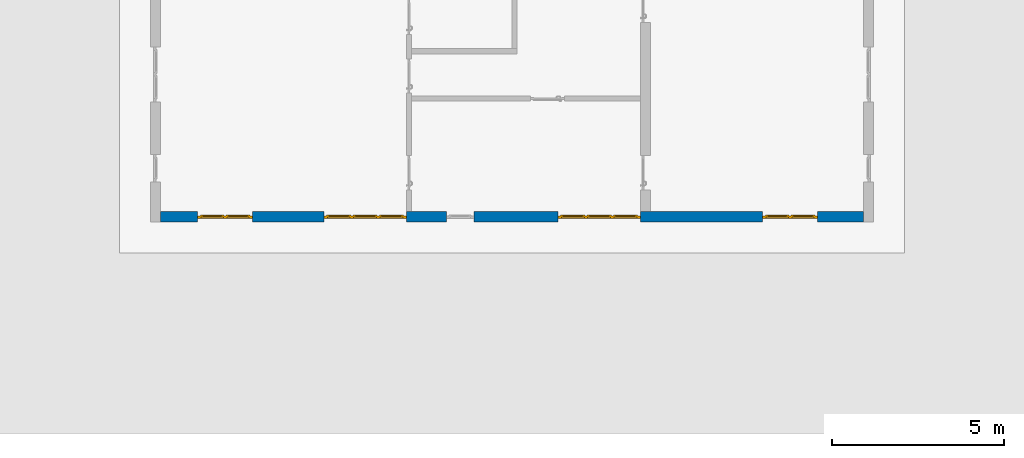
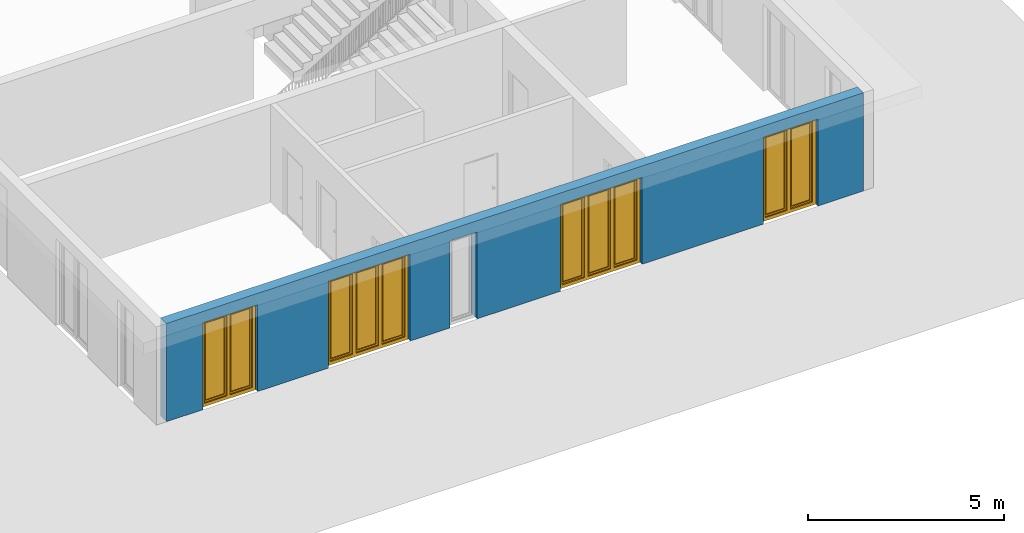
# One storey, part 5 of 23: 4 windows, 1 wall, 5 openings.
"""IFC4 building model written with IfcOpenShell, lengths in metres."""

from ifc_helpers import new_model, entity, si_unit, converted_unit, derived_unit, direction, frame, origin_with_axes, place, context, subcontext, project, spatial, polygons, source, transform, mapped, material, type_object, element, fill, save


model = new_model("IFC4")

# Units and contexts
model_context = context("Model", 3, precision=1e-05, world=origin_with_axes(), true_north=direction((0.0, 1.0)))
body_context = subcontext(model_context, "Body", "Model", "MODEL_VIEW")
ifc_project = project(units=[si_unit("LENGTHUNIT", "METRE"), si_unit("AREAUNIT", "SQUARE_METRE"), si_unit("VOLUMEUNIT", "CUBIC_METRE"), converted_unit("PLANEANGLEUNIT", "DEGREE", entity("IfcPlaneAngleMeasure", 0.0174532925199), si_unit("PLANEANGLEUNIT", "RADIAN"), dimensions=[0, 0, 0, 0, 0, 0, 0]), converted_unit("TIMEUNIT", "Year", entity("IfcTimeMeasure", 31556926.0), si_unit("TIMEUNIT", "SECOND"), dimensions=[0, 0, 1, 0, 0, 0, 0]), si_unit("MASSUNIT", "GRAM", prefix="KILO"), si_unit("THERMODYNAMICTEMPERATUREUNIT", "DEGREE_CELSIUS"), si_unit("LUMINOUSINTENSITYUNIT", "LUMEN"), si_unit("ENERGYUNIT", "JOULE", prefix="MEGA"), derived_unit("THERMALCONDUCTANCEUNIT", [(si_unit("POWERUNIT", "WATT"), 1), (si_unit("LENGTHUNIT", "METRE"), -1), (si_unit("THERMODYNAMICTEMPERATUREUNIT", "KELVIN"), -1)]), derived_unit("SPECIFICHEATCAPACITYUNIT", [(si_unit("ENERGYUNIT", "JOULE"), 1), (si_unit("MASSUNIT", "GRAM", prefix="KILO"), -1), (si_unit("THERMODYNAMICTEMPERATUREUNIT", "KELVIN"), -1)]), derived_unit("MASSDENSITYUNIT", [(si_unit("MASSUNIT", "GRAM", prefix="KILO"), 1), (si_unit("VOLUMEUNIT", "CUBIC_METRE"), -1)])], contexts=[model_context])

# Site, building, storey
site_placement = place(None, origin_with_axes())
site = spatial("IfcSite", under=ifc_project, at=site_placement, CompositionType="ELEMENT")
building_placement = place(site_placement, origin_with_axes())
building = spatial("IfcBuilding", under=site, at=building_placement, CompositionType="ELEMENT")
storey_placement = place(building_placement, origin_with_axes())
storey = spatial("IfcBuildingStorey", under=building, at=storey_placement, Name="0. Geschoss", CompositionType="ELEMENT", Elevation=0.0)

# Wall, openings, windows
ifc_material = material()
wall_type = type_object("IfcWallType", Name="300", PredefinedType="NOTDEFINED")
wall_placement = place(storey_placement, frame((9.3378006196, -9.92881223104, 0.0), z_axis=(0.0, 0.0, 1.0), x_axis=(-1.0, 0.0, 0.0)))
wall = element("IfcWall", 1, at=wall_placement, inside=storey, type_object=wall_type, material=ifc_material, Name="Wand-001", PredefinedType="NOTDEFINED", context=body_context, shape_type="Tessellation", body=[
    polygons([(12.4515538751, -0.3, 2.7), (12.4515538751, -0.3, 0.0), (13.62, -0.3, 0.0), (13.62, -0.3, 2.7), (16.02, -0.3, 2.7), (16.02, -0.3, 0.0), (18.0998837323, -0.3, 0.0), (18.0998837323, -0.3, 2.7), (19.6998837323, -0.3, 2.7), (19.6998837323, -0.3, 0.0), (20.78, -0.3, 0.0), (20.78, -0.3, 3.05), (0.3, -0.3, 3.05), (0.3, -0.3, 0.0), (1.6378225413, -0.3, 0.0), (1.6378225413, -0.3, 2.7), (3.2378225413, -0.3, 2.7), (3.2378225413, -0.3, 0.0), (6.80048177301, -0.3, 0.0), (6.80048177301, -0.3, 2.7), (9.20048177301, -0.3, 2.7), (9.20048177301, -0.3, 0.0), (11.6515538751, -0.3, 0.0), (11.6515538751, -0.3, 2.7), (12.4515538751, -0.1, 0.0), (12.4515538751, 0.0, 2.7), (12.4515538751, 0.0, 0.0), (13.62, 0.0, 0.0), (13.62, 0.0, 2.7), (16.02, 0.0, 2.7), (16.02, 0.0, 0.0), (18.0998837323, 0.0, 0.0), (18.0998837323, 0.0, 2.7), (19.6998837323, 0.0, 2.7), (19.6998837323, 0.0, 0.0), (20.78, 0.0, 0.0), (20.78, 0.0, 3.05), (0.3, 0.0, 3.05), (0.3, 0.0, 0.0), (1.6378225413, 0.0, 0.0), (1.6378225413, 0.0, 2.7), (3.2378225413, 0.0, 2.7), (3.2378225413, 0.0, 0.0), (6.80048177301, 0.0, 0.0), (6.80048177301, 0.0, 2.7), (9.20048177301, 0.0, 2.7), (9.20048177301, 0.0, 0.0), (11.6515538751, -0.1, 0.0), (11.6515538751, 0.0, 0.0), (11.6515538751, 0.0, 2.7)], [[[1, 2, 3, 4, 5, 6, 7, 8, 9, 10, 11, 12, 13, 14, 15, 16, 17, 18, 19, 20, 21, 22, 23, 24]], [[25, 2, 1, 26, 27]], [[2, 25, 27, 28, 3]], [[4, 3, 28, 29]], [[5, 4, 29, 30]], [[6, 5, 30, 31]], [[6, 31, 32, 7]], [[8, 7, 32, 33]], [[9, 8, 33, 34]], [[10, 9, 34, 35]], [[10, 35, 36, 11]], [[12, 11, 36, 37]], [[13, 12, 37, 38]], [[38, 39, 14, 13]], [[39, 40, 15, 14]], [[40, 41, 16, 15]], [[41, 42, 17, 16]], [[42, 43, 18, 17]], [[43, 44, 19, 18]], [[44, 45, 20, 19]], [[45, 46, 21, 20]], [[46, 47, 22, 21]], [[48, 23, 22, 47, 49]], [[24, 23, 48, 49, 50]], [[1, 24, 50, 26]], [[28, 27, 26, 50, 49, 47, 46, 45, 44, 43, 42, 41, 40, 39, 38, 37, 36, 35, 34, 33, 32, 31, 30, 29]]], closed=True),
])
opening_1_placement = place(wall_placement, frame((18.8998837323, 0.0, 0.0), z_axis=(0.0, 0.0, 1.0), x_axis=(1.0, 0.0, 0.0)))
opening_1 = element("IfcOpeningElement", 2, at=opening_1_placement, cuts=wall, Name="Fenster-001", context=body_context, identifier="Reference", shape_type="Tessellation", body=[
    polygons([(-0.8, -0.1, 0.0), (-0.8, -0.1, 2.7), (-0.8, 0.001, 2.7), (-0.8, 0.001, 0.0), (-0.8, -0.301, 0.0), (-0.8, -0.301, 2.7), (0.8, -0.1, 2.7), (0.8, 0.001, 2.7), (0.8, -0.301, 2.7), (0.8, 0.001, 0.0), (0.8, -0.1, 0.0), (0.8, -0.301, 0.0)], [[[1, 2, 3, 4]], [[2, 1, 5, 6]], [[7, 8, 3, 2, 6, 9]], [[8, 10, 4, 3]], [[1, 4, 10, 11, 12, 5]], [[6, 5, 12, 9]], [[7, 11, 10, 8]], [[11, 7, 9, 12]]], closed=True),
])
opening_2_placement = place(wall_placement, frame((2.4378225413, 0.0, 0.0), z_axis=(0.0, 0.0, 1.0), x_axis=(1.0, 0.0, 0.0)))
opening_2 = element("IfcOpeningElement", 3, at=opening_2_placement, cuts=wall, Name="Fenster-002", context=body_context, identifier="Reference", shape_type="Tessellation", body=[
    polygons([(-0.8, -0.1, 0.0), (-0.8, -0.1, 2.7), (-0.8, 0.000999999999999, 2.7), (-0.8, 0.000999999999999, 0.0), (-0.8, -0.301, 0.0), (-0.8, -0.301, 2.7), (0.8, -0.1, 2.7), (0.8, 0.000999999999999, 2.7), (0.8, -0.301, 2.7), (0.8, 0.000999999999999, 0.0), (0.8, -0.1, 0.0), (0.8, -0.301, 0.0)], [[[1, 2, 3, 4]], [[2, 1, 5, 6]], [[7, 8, 3, 2, 6, 9]], [[8, 10, 4, 3]], [[1, 4, 10, 11, 12, 5]], [[6, 5, 12, 9]], [[7, 11, 10, 8]], [[11, 7, 9, 12]]], closed=True),
])
opening_3_placement = place(wall_placement, frame((14.82, 0.0, 0.0), z_axis=(0.0, 0.0, 1.0), x_axis=(1.0, 0.0, 0.0)))
opening_3 = element("IfcOpeningElement", 4, at=opening_3_placement, cuts=wall, Name="Fenster-002", context=body_context, identifier="Reference", shape_type="Tessellation", body=[
    polygons([(-1.2, -0.1, 0.0), (-1.2, -0.1, 2.7), (-1.2, 0.001, 2.7), (-1.2, 0.001, 0.0), (-1.2, -0.301, 0.0), (-1.2, -0.301, 2.7), (1.2, -0.1, 2.7), (1.2, 0.001, 2.7), (1.2, -0.301, 2.7), (1.2, 0.001, 0.0), (1.2, -0.1, 0.0), (1.2, -0.301, 0.0)], [[[1, 2, 3, 4]], [[2, 1, 5, 6]], [[7, 8, 3, 2, 6, 9]], [[8, 10, 4, 3]], [[1, 4, 10, 11, 12, 5]], [[6, 5, 12, 9]], [[7, 11, 10, 8]], [[11, 7, 9, 12]]], closed=True),
])
opening_4_placement = place(wall_placement, frame((8.00048177301, 0.0, 0.0), z_axis=(0.0, 0.0, 1.0), x_axis=(1.0, 0.0, 0.0)))
opening_4 = element("IfcOpeningElement", 5, at=opening_4_placement, cuts=wall, Name="Fenster-003", context=body_context, identifier="Reference", shape_type="Tessellation", body=[
    polygons([(-1.2, -0.1, 0.0), (-1.2, -0.1, 2.7), (-1.2, 0.001, 2.7), (-1.2, 0.001, 0.0), (-1.2, -0.301, 0.0), (-1.2, -0.301, 2.7), (1.2, -0.1, 2.7), (1.2, 0.001, 2.7), (1.2, -0.301, 2.7), (1.2, 0.001, 0.0), (1.2, -0.1, 0.0), (1.2, -0.301, 0.0)], [[[1, 2, 3, 4]], [[2, 1, 5, 6]], [[7, 8, 3, 2, 6, 9]], [[8, 10, 4, 3]], [[1, 4, 10, 11, 12, 5]], [[6, 5, 12, 9]], [[7, 11, 10, 8]], [[11, 7, 9, 12]]], closed=True),
])
opening_5_placement = place(wall_placement, frame((12.0515538751, 0.0, 0.0), z_axis=(0.0, 0.0, 1.0), x_axis=(1.0, 0.0, 0.0)))
element("IfcOpeningElement", 6, at=opening_5_placement, cuts=wall, Name="Fenster-003", context=body_context, identifier="Reference", shape_type="Tessellation", body=[
    polygons([(-0.4, -0.1, 0.0), (-0.4, -0.1, 2.7), (-0.4, 0.001, 2.7), (-0.4, 0.001, 0.0), (-0.4, -0.301, 0.0), (-0.4, -0.301, 2.7), (0.4, -0.1, 2.7), (0.4, 0.001, 2.7), (0.4, -0.301, 2.7), (0.4, 0.001, 0.0), (0.4, -0.1, 0.0), (0.4, -0.301, 0.0)], [[[1, 2, 3, 4]], [[2, 1, 5, 6]], [[7, 8, 3, 2, 6, 9]], [[8, 10, 4, 3]], [[1, 4, 10, 11, 12, 5]], [[6, 5, 12, 9]], [[7, 11, 10, 8]], [[11, 7, 9, 12]]], closed=True),
])
window_type_1 = type_object("IfcWindowType", Name="2-1+1 26", PartitioningType="DOUBLE_PANEL_VERTICAL", PredefinedType="WINDOW")
shared_shape_1 = source(origin_with_axes(), body_context, "Body", "Tessellation", [
    polygons([(-0.8, -0.07, 0.0), (-0.8, 0.0, 0.0), (-0.7, 0.0, 0.1), (-0.7, -0.07, 0.1), (-0.8, -0.07, 2.7), (-0.8, 0.0, 2.7), (-0.7, 0.0, 2.6), (-0.7, -0.07, 2.6)], [[[1, 2, 3, 4]], [[5, 6, 2, 1]], [[2, 6, 7, 3]], [[4, 3, 7, 8]], [[1, 4, 8, 5]], [[8, 7, 6, 5]]], closed=True),
    polygons([(0.8, -0.07, 0.0), (0.8, 0.0, 0.0), (0.8, 0.0, 2.7), (0.8, -0.07, 2.7), (0.7, -0.07, 0.1), (0.7, 0.0, 0.1), (0.7, 0.0, 2.6), (0.7, -0.07, 2.6)], [[[1, 2, 3, 4]], [[5, 6, 2, 1]], [[2, 6, 7, 3]], [[4, 3, 7, 8]], [[1, 4, 8, 5]], [[8, 7, 6, 5]]], closed=True),
    polygons([(-0.8, -0.07, 0.0), (-0.8, 0.0, 0.0), (0.8, 0.0, 0.0), (0.8, -0.07, 0.0), (-0.7, -0.07, 0.1), (-0.7, 0.0, 0.1), (-0.05, 0.0, 0.1), (0.05, 0.0, 0.1), (0.7, 0.0, 0.1), (0.7, -0.07, 0.1), (0.05, -0.07, 0.1), (-0.05, -0.07, 0.1)], [[[1, 2, 3, 4]], [[5, 6, 2, 1]], [[2, 6, 7, 8, 9, 3]], [[4, 3, 9, 10]], [[1, 4, 10, 11, 12, 5]], [[12, 7, 6, 5]], [[11, 8, 7, 12]], [[10, 9, 8, 11]]], closed=True),
    polygons([(-0.8, -0.07, 2.7), (-0.8, 0.0, 2.7), (-0.7, 0.0, 2.6), (-0.7, -0.07, 2.6), (0.8, -0.07, 2.7), (0.8, 0.0, 2.7), (0.7, 0.0, 2.6), (0.05, 0.0, 2.6), (-0.05, 0.0, 2.6), (-0.05, -0.07, 2.6), (0.05, -0.07, 2.6), (0.7, -0.07, 2.6)], [[[1, 2, 3, 4]], [[5, 6, 2, 1]], [[2, 6, 7, 8, 9, 3]], [[4, 3, 9, 10]], [[1, 4, 10, 11, 12, 5]], [[12, 7, 6, 5]], [[11, 8, 7, 12]], [[10, 9, 8, 11]]], closed=True),
    polygons([(-0.05, -0.07, 0.1), (-0.05, 0.0, 0.1), (0.05, 0.0, 0.1), (0.05, -0.07, 0.1), (-0.05, -0.07, 2.6), (-0.05, 0.0, 2.6), (0.05, 0.0, 2.6), (0.05, -0.07, 2.6)], [[[1, 2, 3, 4]], [[5, 6, 2, 1]], [[2, 6, 7, 3]], [[4, 3, 7, 8]], [[1, 4, 8, 5]], [[8, 7, 6, 5]]], closed=True),
    polygons([(-0.72, 0.0, 0.08), (-0.72, 0.03, 0.08), (-0.65, 0.03, 0.15), (-0.65, 0.0, 0.15), (-0.72, 0.0, 2.62), (-0.72, 0.03, 2.62), (-0.65, 0.03, 2.55), (-0.65, 0.0, 2.55)], [[[1, 2, 3, 4]], [[5, 6, 2, 1]], [[2, 6, 7, 3]], [[4, 3, 7, 8]], [[1, 4, 8, 5]], [[8, 7, 6, 5]]], closed=True),
    polygons([(-0.03, 0.0, 0.08), (-0.1, 0.0, 0.15), (-0.1, 0.03, 0.15), (-0.03, 0.03, 0.08), (-0.03, 0.0, 2.62), (-0.1, 0.0, 2.55), (-0.1, 0.03, 2.55), (-0.03, 0.03, 2.62)], [[[1, 2, 3, 4]], [[1, 5, 6, 2]], [[2, 6, 7, 3]], [[4, 3, 7, 8]], [[5, 1, 4, 8]], [[6, 5, 8, 7]]], closed=True),
    polygons([(-0.72, 0.0, 0.08), (-0.72, 0.03, 0.08), (-0.03, 0.03, 0.08), (-0.03, 0.0, 0.08), (-0.65, 0.0, 0.15), (-0.65, 0.03, 0.15), (-0.1, 0.03, 0.15), (-0.1, 0.0, 0.15)], [[[1, 2, 3, 4]], [[5, 6, 2, 1]], [[2, 6, 7, 3]], [[4, 3, 7, 8]], [[1, 4, 8, 5]], [[8, 7, 6, 5]]], closed=True),
    polygons([(-0.72, 0.0, 2.62), (-0.03, 0.0, 2.62), (-0.03, 0.03, 2.62), (-0.72, 0.03, 2.62), (-0.65, 0.0, 2.55), (-0.1, 0.0, 2.55), (-0.1, 0.03, 2.55), (-0.65, 0.03, 2.55)], [[[1, 2, 3, 4]], [[1, 5, 6, 2]], [[2, 6, 7, 3]], [[4, 3, 7, 8]], [[5, 1, 4, 8]], [[6, 5, 8, 7]]], closed=True),
    polygons([(-0.7, -0.03, 0.1), (-0.7, 0.0, 0.1), (-0.65, 0.0, 0.15), (-0.65, -0.03, 0.15), (-0.7, -0.03, 2.6), (-0.7, 0.0, 2.6), (-0.65, 0.0, 2.55), (-0.65, -0.03, 2.55)], [[[1, 2, 3, 4]], [[5, 6, 2, 1]], [[2, 6, 7, 3]], [[4, 3, 7, 8]], [[1, 4, 8, 5]], [[8, 7, 6, 5]]], closed=True),
    polygons([(-0.05, -0.03, 0.1), (-0.1, -0.03, 0.15), (-0.1, 0.0, 0.15), (-0.05, 0.0, 0.1), (-0.05, -0.03, 2.6), (-0.1, -0.03, 2.55), (-0.1, 0.0, 2.55), (-0.05, 0.0, 2.6)], [[[1, 2, 3, 4]], [[1, 5, 6, 2]], [[2, 6, 7, 3]], [[4, 3, 7, 8]], [[5, 1, 4, 8]], [[6, 5, 8, 7]]], closed=True),
    polygons([(-0.7, -0.03, 0.1), (-0.7, 0.0, 0.1), (-0.05, 0.0, 0.1), (-0.05, -0.03, 0.1), (-0.65, -0.03, 0.15), (-0.65, 0.0, 0.15), (-0.1, 0.0, 0.15), (-0.1, -0.03, 0.15)], [[[1, 2, 3, 4]], [[5, 6, 2, 1]], [[2, 6, 7, 3]], [[4, 3, 7, 8]], [[1, 4, 8, 5]], [[8, 7, 6, 5]]], closed=True),
    polygons([(-0.7, -0.03, 2.6), (-0.05, -0.03, 2.6), (-0.05, 0.0, 2.6), (-0.7, 0.0, 2.6), (-0.65, -0.03, 2.55), (-0.1, -0.03, 2.55), (-0.1, 0.0, 2.55), (-0.65, 0.0, 2.55)], [[[1, 2, 3, 4]], [[1, 5, 6, 2]], [[2, 6, 7, 3]], [[4, 3, 7, 8]], [[5, 1, 4, 8]], [[6, 5, 8, 7]]], closed=True),
    polygons([(-0.65, -0.005, 0.15), (-0.65, 0.005, 0.15), (-0.1, 0.005, 0.15), (-0.1, -0.005, 0.15), (-0.65, -0.005, 2.55), (-0.65, 0.005, 2.55), (-0.1, 0.005, 2.55), (-0.1, -0.005, 2.55)], [[[1, 2, 3, 4]], [[5, 6, 2, 1]], [[2, 6, 7, 3]], [[4, 3, 7, 8]], [[1, 4, 8, 5]], [[8, 7, 6, 5]]], closed=True),
    polygons([(0.03, 0.0, 0.08), (0.03, 0.03, 0.08), (0.1, 0.03, 0.15), (0.1, 0.0, 0.15), (0.03, 0.0, 2.62), (0.03, 0.03, 2.62), (0.1, 0.03, 2.55), (0.1, 0.0, 2.55)], [[[1, 2, 3, 4]], [[5, 6, 2, 1]], [[2, 6, 7, 3]], [[4, 3, 7, 8]], [[1, 4, 8, 5]], [[8, 7, 6, 5]]], closed=True),
    polygons([(0.72, 0.0, 0.08), (0.65, 0.0, 0.15), (0.65, 0.03, 0.15), (0.72, 0.03, 0.08), (0.72, 0.0, 2.62), (0.65, 0.0, 2.55), (0.65, 0.03, 2.55), (0.72, 0.03, 2.62)], [[[1, 2, 3, 4]], [[1, 5, 6, 2]], [[2, 6, 7, 3]], [[4, 3, 7, 8]], [[5, 1, 4, 8]], [[6, 5, 8, 7]]], closed=True),
    polygons([(0.03, 0.0, 0.08), (0.03, 0.03, 0.08), (0.72, 0.03, 0.08), (0.72, 0.0, 0.08), (0.1, 0.0, 0.15), (0.1, 0.03, 0.15), (0.65, 0.03, 0.15), (0.65, 0.0, 0.15)], [[[1, 2, 3, 4]], [[5, 6, 2, 1]], [[2, 6, 7, 3]], [[4, 3, 7, 8]], [[1, 4, 8, 5]], [[8, 7, 6, 5]]], closed=True),
    polygons([(0.03, 0.0, 2.62), (0.72, 0.0, 2.62), (0.72, 0.03, 2.62), (0.03, 0.03, 2.62), (0.1, 0.0, 2.55), (0.65, 0.0, 2.55), (0.65, 0.03, 2.55), (0.1, 0.03, 2.55)], [[[1, 2, 3, 4]], [[1, 5, 6, 2]], [[2, 6, 7, 3]], [[4, 3, 7, 8]], [[5, 1, 4, 8]], [[6, 5, 8, 7]]], closed=True),
    polygons([(0.05, -0.03, 0.1), (0.05, 0.0, 0.1), (0.1, 0.0, 0.15), (0.1, -0.03, 0.15), (0.05, -0.03, 2.6), (0.05, 0.0, 2.6), (0.1, 0.0, 2.55), (0.1, -0.03, 2.55)], [[[1, 2, 3, 4]], [[5, 6, 2, 1]], [[2, 6, 7, 3]], [[4, 3, 7, 8]], [[1, 4, 8, 5]], [[8, 7, 6, 5]]], closed=True),
    polygons([(0.7, -0.03, 0.1), (0.65, -0.03, 0.15), (0.65, 0.0, 0.15), (0.7, 0.0, 0.1), (0.7, -0.03, 2.6), (0.65, -0.03, 2.55), (0.65, 0.0, 2.55), (0.7, 0.0, 2.6)], [[[1, 2, 3, 4]], [[1, 5, 6, 2]], [[2, 6, 7, 3]], [[4, 3, 7, 8]], [[5, 1, 4, 8]], [[6, 5, 8, 7]]], closed=True),
    polygons([(0.05, -0.03, 0.1), (0.05, 0.0, 0.1), (0.7, 0.0, 0.1), (0.7, -0.03, 0.1), (0.1, -0.03, 0.15), (0.1, 0.0, 0.15), (0.65, 0.0, 0.15), (0.65, -0.03, 0.15)], [[[1, 2, 3, 4]], [[5, 6, 2, 1]], [[2, 6, 7, 3]], [[4, 3, 7, 8]], [[1, 4, 8, 5]], [[8, 7, 6, 5]]], closed=True),
    polygons([(0.05, -0.03, 2.6), (0.7, -0.03, 2.6), (0.7, 0.0, 2.6), (0.05, 0.0, 2.6), (0.1, -0.03, 2.55), (0.65, -0.03, 2.55), (0.65, 0.0, 2.55), (0.1, 0.0, 2.55)], [[[1, 2, 3, 4]], [[1, 5, 6, 2]], [[2, 6, 7, 3]], [[4, 3, 7, 8]], [[5, 1, 4, 8]], [[6, 5, 8, 7]]], closed=True),
    polygons([(0.1, -0.005, 0.15), (0.1, 0.005, 0.15), (0.65, 0.005, 0.15), (0.65, -0.005, 0.15), (0.1, -0.005, 2.55), (0.1, 0.005, 2.55), (0.65, 0.005, 2.55), (0.65, -0.005, 2.55)], [[[1, 2, 3, 4]], [[5, 6, 2, 1]], [[2, 6, 7, 3]], [[4, 3, 7, 8]], [[1, 4, 8, 5]], [[8, 7, 6, 5]]], closed=True),
])
window_1_placement = place(opening_1_placement, frame((0.8, 0.0, 0.0), z_axis=(0.0, 0.0, 1.0), x_axis=(-1.0, 0.0, 0.0)))
window_1 = element("IfcWindow", 7, at=window_1_placement, inside=storey, type_object=window_type_1, Name="Fenster-001", OverallHeight=2.7, OverallWidth=1.6, PredefinedType="WINDOW", context=body_context, shape_type="MappedRepresentation", body=[
    mapped(shared_shape_1, transform((0.8, 0.17, 0.0))),
])
fill(opening_1, window_1)
window_2_placement = place(opening_2_placement, frame((0.8, 0.0, 0.0), z_axis=(0.0, 0.0, 1.0), x_axis=(-1.0, 0.0, 0.0)))
window_2 = element("IfcWindow", 8, at=window_2_placement, inside=storey, type_object=window_type_1, Name="Fenster-002", OverallHeight=2.7, OverallWidth=1.6, PredefinedType="WINDOW", context=body_context, shape_type="MappedRepresentation", body=[
    mapped(shared_shape_1, transform((0.8, 0.17, 0.0))),
])
fill(opening_2, window_2)
window_type_2 = type_object("IfcWindowType", Name="3-1+1+1 26", PartitioningType="TRIPLE_PANEL_VERTICAL", PredefinedType="WINDOW")
shared_shape_2 = source(origin_with_axes(), body_context, "Body", "Tessellation", [
    polygons([(-1.2, -0.07, 0.0), (-1.2, 0.0, 0.0), (-1.1, 0.0, 0.1), (-1.1, -0.07, 0.1), (-1.2, -0.07, 2.7), (-1.2, 0.0, 2.7), (-1.1, 0.0, 2.6), (-1.1, -0.07, 2.6)], [[[1, 2, 3, 4]], [[5, 6, 2, 1]], [[2, 6, 7, 3]], [[4, 3, 7, 8]], [[1, 4, 8, 5]], [[8, 7, 6, 5]]], closed=True),
    polygons([(1.2, -0.07, 0.0), (1.2, 0.0, 0.0), (1.2, 0.0, 2.7), (1.2, -0.07, 2.7), (1.1, -0.07, 0.1), (1.1, 0.0, 0.1), (1.1, 0.0, 2.6), (1.1, -0.07, 2.6)], [[[1, 2, 3, 4]], [[5, 6, 2, 1]], [[2, 6, 7, 3]], [[4, 3, 7, 8]], [[1, 4, 8, 5]], [[8, 7, 6, 5]]], closed=True),
    polygons([(-1.2, -0.07, 0.0), (-1.2, 0.0, 0.0), (1.2, 0.0, 0.0), (1.2, -0.07, 0.0), (-1.1, -0.07, 0.1), (-1.1, 0.0, 0.1), (-0.433333333333, 0.0, 0.1), (-0.333333333333, 0.0, 0.1), (0.333333333333, 0.0, 0.1), (0.433333333333, 0.0, 0.1), (1.1, 0.0, 0.1), (1.1, -0.07, 0.1), (0.433333333333, -0.07, 0.1), (0.333333333333, -0.07, 0.1), (-0.333333333333, -0.07, 0.1), (-0.433333333333, -0.07, 0.1)], [[[1, 2, 3, 4]], [[5, 6, 2, 1]], [[2, 6, 7, 8, 9, 10, 11, 3]], [[4, 3, 11, 12]], [[1, 4, 12, 13, 14, 15, 16, 5]], [[16, 7, 6, 5]], [[15, 8, 7, 16]], [[14, 9, 8, 15]], [[13, 10, 9, 14]], [[12, 11, 10, 13]]], closed=True),
    polygons([(-1.2, -0.07, 2.7), (-1.2, 0.0, 2.7), (-1.1, 0.0, 2.6), (-1.1, -0.07, 2.6), (1.2, -0.07, 2.7), (1.2, 0.0, 2.7), (1.1, 0.0, 2.6), (0.433333333333, 0.0, 2.6), (0.333333333333, 0.0, 2.6), (-0.333333333333, 0.0, 2.6), (-0.433333333333, 0.0, 2.6), (-0.433333333333, -0.07, 2.6), (-0.333333333333, -0.07, 2.6), (0.333333333333, -0.07, 2.6), (0.433333333333, -0.07, 2.6), (1.1, -0.07, 2.6)], [[[1, 2, 3, 4]], [[5, 6, 2, 1]], [[2, 6, 7, 8, 9, 10, 11, 3]], [[4, 3, 11, 12]], [[1, 4, 12, 13, 14, 15, 16, 5]], [[16, 7, 6, 5]], [[15, 8, 7, 16]], [[14, 9, 8, 15]], [[13, 10, 9, 14]], [[12, 11, 10, 13]]], closed=True),
    polygons([(0.333333333333, -0.07, 0.1), (0.333333333333, 0.0, 0.1), (0.433333333333, 0.0, 0.1), (0.433333333333, -0.07, 0.1), (0.333333333333, -0.07, 2.6), (0.333333333333, 0.0, 2.6), (0.433333333333, 0.0, 2.6), (0.433333333333, -0.07, 2.6)], [[[1, 2, 3, 4]], [[5, 6, 2, 1]], [[2, 6, 7, 3]], [[4, 3, 7, 8]], [[1, 4, 8, 5]], [[8, 7, 6, 5]]], closed=True),
    polygons([(-0.433333333333, -0.07, 0.1), (-0.433333333333, 0.0, 0.1), (-0.333333333333, 0.0, 0.1), (-0.333333333333, -0.07, 0.1), (-0.433333333333, -0.07, 2.6), (-0.433333333333, 0.0, 2.6), (-0.333333333333, 0.0, 2.6), (-0.333333333333, -0.07, 2.6)], [[[1, 2, 3, 4]], [[5, 6, 2, 1]], [[2, 6, 7, 3]], [[4, 3, 7, 8]], [[1, 4, 8, 5]], [[8, 7, 6, 5]]], closed=True),
    polygons([(-1.12, 0.0, 0.08), (-1.12, 0.03, 0.08), (-1.05, 0.03, 0.15), (-1.05, 0.0, 0.15), (-1.12, 0.0, 2.62), (-1.12, 0.03, 2.62), (-1.05, 0.03, 2.55), (-1.05, 0.0, 2.55)], [[[1, 2, 3, 4]], [[5, 6, 2, 1]], [[2, 6, 7, 3]], [[4, 3, 7, 8]], [[1, 4, 8, 5]], [[8, 7, 6, 5]]], closed=True),
    polygons([(-0.413333333333, 0.0, 0.08), (-0.483333333333, 0.0, 0.15), (-0.483333333333, 0.03, 0.15), (-0.413333333333, 0.03, 0.08), (-0.413333333333, 0.0, 2.62), (-0.483333333333, 0.0, 2.55), (-0.483333333333, 0.03, 2.55), (-0.413333333333, 0.03, 2.62)], [[[1, 2, 3, 4]], [[1, 5, 6, 2]], [[2, 6, 7, 3]], [[4, 3, 7, 8]], [[5, 1, 4, 8]], [[6, 5, 8, 7]]], closed=True),
    polygons([(-1.12, 0.0, 0.08), (-1.12, 0.03, 0.08), (-0.413333333333, 0.03, 0.08), (-0.413333333333, 0.0, 0.08), (-1.05, 0.0, 0.15), (-1.05, 0.03, 0.15), (-0.483333333333, 0.03, 0.15), (-0.483333333333, 0.0, 0.15)], [[[1, 2, 3, 4]], [[5, 6, 2, 1]], [[2, 6, 7, 3]], [[4, 3, 7, 8]], [[1, 4, 8, 5]], [[8, 7, 6, 5]]], closed=True),
    polygons([(-1.12, 0.0, 2.62), (-0.413333333333, 0.0, 2.62), (-0.413333333333, 0.03, 2.62), (-1.12, 0.03, 2.62), (-1.05, 0.0, 2.55), (-0.483333333333, 0.0, 2.55), (-0.483333333333, 0.03, 2.55), (-1.05, 0.03, 2.55)], [[[1, 2, 3, 4]], [[1, 5, 6, 2]], [[2, 6, 7, 3]], [[4, 3, 7, 8]], [[5, 1, 4, 8]], [[6, 5, 8, 7]]], closed=True),
    polygons([(-1.1, -0.03, 0.1), (-1.1, 0.0, 0.1), (-1.05, 0.0, 0.15), (-1.05, -0.03, 0.15), (-1.1, -0.03, 2.6), (-1.1, 0.0, 2.6), (-1.05, 0.0, 2.55), (-1.05, -0.03, 2.55)], [[[1, 2, 3, 4]], [[5, 6, 2, 1]], [[2, 6, 7, 3]], [[4, 3, 7, 8]], [[1, 4, 8, 5]], [[8, 7, 6, 5]]], closed=True),
    polygons([(-0.433333333333, -0.03, 0.1), (-0.483333333333, -0.03, 0.15), (-0.483333333333, 0.0, 0.15), (-0.433333333333, 0.0, 0.1), (-0.433333333333, -0.03, 2.6), (-0.483333333333, -0.03, 2.55), (-0.483333333333, 0.0, 2.55), (-0.433333333333, 0.0, 2.6)], [[[1, 2, 3, 4]], [[1, 5, 6, 2]], [[2, 6, 7, 3]], [[4, 3, 7, 8]], [[5, 1, 4, 8]], [[6, 5, 8, 7]]], closed=True),
    polygons([(-1.1, -0.03, 0.1), (-1.1, 0.0, 0.1), (-0.433333333333, 0.0, 0.1), (-0.433333333333, -0.03, 0.1), (-1.05, -0.03, 0.15), (-1.05, 0.0, 0.15), (-0.483333333333, 0.0, 0.15), (-0.483333333333, -0.03, 0.15)], [[[1, 2, 3, 4]], [[5, 6, 2, 1]], [[2, 6, 7, 3]], [[4, 3, 7, 8]], [[1, 4, 8, 5]], [[8, 7, 6, 5]]], closed=True),
    polygons([(-1.1, -0.03, 2.6), (-0.433333333333, -0.03, 2.6), (-0.433333333333, 0.0, 2.6), (-1.1, 0.0, 2.6), (-1.05, -0.03, 2.55), (-0.483333333333, -0.03, 2.55), (-0.483333333333, 0.0, 2.55), (-1.05, 0.0, 2.55)], [[[1, 2, 3, 4]], [[1, 5, 6, 2]], [[2, 6, 7, 3]], [[4, 3, 7, 8]], [[5, 1, 4, 8]], [[6, 5, 8, 7]]], closed=True),
    polygons([(-1.05, -0.005, 0.15), (-1.05, 0.005, 0.15), (-0.483333333333, 0.005, 0.15), (-0.483333333333, -0.005, 0.15), (-1.05, -0.005, 2.55), (-1.05, 0.005, 2.55), (-0.483333333333, 0.005, 2.55), (-0.483333333333, -0.005, 2.55)], [[[1, 2, 3, 4]], [[5, 6, 2, 1]], [[2, 6, 7, 3]], [[4, 3, 7, 8]], [[1, 4, 8, 5]], [[8, 7, 6, 5]]], closed=True),
    polygons([(-0.353333333333, 0.0, 0.08), (-0.353333333333, 0.03, 0.08), (-0.283333333333, 0.03, 0.15), (-0.283333333333, 0.0, 0.15), (-0.353333333333, 0.0, 2.62), (-0.353333333333, 0.03, 2.62), (-0.283333333333, 0.03, 2.55), (-0.283333333333, 0.0, 2.55)], [[[1, 2, 3, 4]], [[5, 6, 2, 1]], [[2, 6, 7, 3]], [[4, 3, 7, 8]], [[1, 4, 8, 5]], [[8, 7, 6, 5]]], closed=True),
    polygons([(0.353333333333, 0.0, 0.08), (0.283333333333, 0.0, 0.15), (0.283333333333, 0.03, 0.15), (0.353333333333, 0.03, 0.08), (0.353333333333, 0.0, 2.62), (0.283333333333, 0.0, 2.55), (0.283333333333, 0.03, 2.55), (0.353333333333, 0.03, 2.62)], [[[1, 2, 3, 4]], [[1, 5, 6, 2]], [[2, 6, 7, 3]], [[4, 3, 7, 8]], [[5, 1, 4, 8]], [[6, 5, 8, 7]]], closed=True),
    polygons([(-0.353333333333, 0.0, 0.08), (-0.353333333333, 0.03, 0.08), (0.353333333333, 0.03, 0.08), (0.353333333333, 0.0, 0.08), (-0.283333333333, 0.0, 0.15), (-0.283333333333, 0.03, 0.15), (0.283333333333, 0.03, 0.15), (0.283333333333, 0.0, 0.15)], [[[1, 2, 3, 4]], [[5, 6, 2, 1]], [[2, 6, 7, 3]], [[4, 3, 7, 8]], [[1, 4, 8, 5]], [[8, 7, 6, 5]]], closed=True),
    polygons([(-0.353333333333, 0.0, 2.62), (0.353333333333, 0.0, 2.62), (0.353333333333, 0.03, 2.62), (-0.353333333333, 0.03, 2.62), (-0.283333333333, 0.0, 2.55), (0.283333333333, 0.0, 2.55), (0.283333333333, 0.03, 2.55), (-0.283333333333, 0.03, 2.55)], [[[1, 2, 3, 4]], [[1, 5, 6, 2]], [[2, 6, 7, 3]], [[4, 3, 7, 8]], [[5, 1, 4, 8]], [[6, 5, 8, 7]]], closed=True),
    polygons([(-0.333333333333, -0.03, 0.1), (-0.333333333333, 0.0, 0.1), (-0.283333333333, 0.0, 0.15), (-0.283333333333, -0.03, 0.15), (-0.333333333333, -0.03, 2.6), (-0.333333333333, 0.0, 2.6), (-0.283333333333, 0.0, 2.55), (-0.283333333333, -0.03, 2.55)], [[[1, 2, 3, 4]], [[5, 6, 2, 1]], [[2, 6, 7, 3]], [[4, 3, 7, 8]], [[1, 4, 8, 5]], [[8, 7, 6, 5]]], closed=True),
    polygons([(0.333333333333, -0.03, 0.1), (0.283333333333, -0.03, 0.15), (0.283333333333, 0.0, 0.15), (0.333333333333, 0.0, 0.1), (0.333333333333, -0.03, 2.6), (0.283333333333, -0.03, 2.55), (0.283333333333, 0.0, 2.55), (0.333333333333, 0.0, 2.6)], [[[1, 2, 3, 4]], [[1, 5, 6, 2]], [[2, 6, 7, 3]], [[4, 3, 7, 8]], [[5, 1, 4, 8]], [[6, 5, 8, 7]]], closed=True),
    polygons([(-0.333333333333, -0.03, 0.1), (-0.333333333333, 0.0, 0.1), (0.333333333333, 0.0, 0.1), (0.333333333333, -0.03, 0.1), (-0.283333333333, -0.03, 0.15), (-0.283333333333, 0.0, 0.15), (0.283333333333, 0.0, 0.15), (0.283333333333, -0.03, 0.15)], [[[1, 2, 3, 4]], [[5, 6, 2, 1]], [[2, 6, 7, 3]], [[4, 3, 7, 8]], [[1, 4, 8, 5]], [[8, 7, 6, 5]]], closed=True),
    polygons([(-0.333333333333, -0.03, 2.6), (0.333333333333, -0.03, 2.6), (0.333333333333, 0.0, 2.6), (-0.333333333333, 0.0, 2.6), (-0.283333333333, -0.03, 2.55), (0.283333333333, -0.03, 2.55), (0.283333333333, 0.0, 2.55), (-0.283333333333, 0.0, 2.55)], [[[1, 2, 3, 4]], [[1, 5, 6, 2]], [[2, 6, 7, 3]], [[4, 3, 7, 8]], [[5, 1, 4, 8]], [[6, 5, 8, 7]]], closed=True),
    polygons([(-0.283333333333, -0.005, 0.15), (-0.283333333333, 0.005, 0.15), (0.283333333333, 0.005, 0.15), (0.283333333333, -0.005, 0.15), (-0.283333333333, -0.005, 2.55), (-0.283333333333, 0.005, 2.55), (0.283333333333, 0.005, 2.55), (0.283333333333, -0.005, 2.55)], [[[1, 2, 3, 4]], [[5, 6, 2, 1]], [[2, 6, 7, 3]], [[4, 3, 7, 8]], [[1, 4, 8, 5]], [[8, 7, 6, 5]]], closed=True),
    polygons([(0.413333333333, 0.0, 0.08), (0.413333333333, 0.03, 0.08), (0.483333333333, 0.03, 0.15), (0.483333333333, 0.0, 0.15), (0.413333333333, 0.0, 2.62), (0.413333333333, 0.03, 2.62), (0.483333333333, 0.03, 2.55), (0.483333333333, 0.0, 2.55)], [[[1, 2, 3, 4]], [[5, 6, 2, 1]], [[2, 6, 7, 3]], [[4, 3, 7, 8]], [[1, 4, 8, 5]], [[8, 7, 6, 5]]], closed=True),
    polygons([(1.12, 0.0, 0.08), (1.05, 0.0, 0.15), (1.05, 0.03, 0.15), (1.12, 0.03, 0.08), (1.12, 0.0, 2.62), (1.05, 0.0, 2.55), (1.05, 0.03, 2.55), (1.12, 0.03, 2.62)], [[[1, 2, 3, 4]], [[1, 5, 6, 2]], [[2, 6, 7, 3]], [[4, 3, 7, 8]], [[5, 1, 4, 8]], [[6, 5, 8, 7]]], closed=True),
    polygons([(0.413333333333, 0.0, 0.08), (0.413333333333, 0.03, 0.08), (1.12, 0.03, 0.08), (1.12, 0.0, 0.08), (0.483333333333, 0.0, 0.15), (0.483333333333, 0.03, 0.15), (1.05, 0.03, 0.15), (1.05, 0.0, 0.15)], [[[1, 2, 3, 4]], [[5, 6, 2, 1]], [[2, 6, 7, 3]], [[4, 3, 7, 8]], [[1, 4, 8, 5]], [[8, 7, 6, 5]]], closed=True),
    polygons([(0.413333333333, 0.0, 2.62), (1.12, 0.0, 2.62), (1.12, 0.03, 2.62), (0.413333333333, 0.03, 2.62), (0.483333333333, 0.0, 2.55), (1.05, 0.0, 2.55), (1.05, 0.03, 2.55), (0.483333333333, 0.03, 2.55)], [[[1, 2, 3, 4]], [[1, 5, 6, 2]], [[2, 6, 7, 3]], [[4, 3, 7, 8]], [[5, 1, 4, 8]], [[6, 5, 8, 7]]], closed=True),
    polygons([(0.433333333333, -0.03, 0.1), (0.433333333333, 0.0, 0.1), (0.483333333333, 0.0, 0.15), (0.483333333333, -0.03, 0.15), (0.433333333333, -0.03, 2.6), (0.433333333333, 0.0, 2.6), (0.483333333333, 0.0, 2.55), (0.483333333333, -0.03, 2.55)], [[[1, 2, 3, 4]], [[5, 6, 2, 1]], [[2, 6, 7, 3]], [[4, 3, 7, 8]], [[1, 4, 8, 5]], [[8, 7, 6, 5]]], closed=True),
    polygons([(1.1, -0.03, 0.1), (1.05, -0.03, 0.15), (1.05, 0.0, 0.15), (1.1, 0.0, 0.1), (1.1, -0.03, 2.6), (1.05, -0.03, 2.55), (1.05, 0.0, 2.55), (1.1, 0.0, 2.6)], [[[1, 2, 3, 4]], [[1, 5, 6, 2]], [[2, 6, 7, 3]], [[4, 3, 7, 8]], [[5, 1, 4, 8]], [[6, 5, 8, 7]]], closed=True),
    polygons([(0.433333333333, -0.03, 0.1), (0.433333333333, 0.0, 0.1), (1.1, 0.0, 0.1), (1.1, -0.03, 0.1), (0.483333333333, -0.03, 0.15), (0.483333333333, 0.0, 0.15), (1.05, 0.0, 0.15), (1.05, -0.03, 0.15)], [[[1, 2, 3, 4]], [[5, 6, 2, 1]], [[2, 6, 7, 3]], [[4, 3, 7, 8]], [[1, 4, 8, 5]], [[8, 7, 6, 5]]], closed=True),
    polygons([(0.433333333333, -0.03, 2.6), (1.1, -0.03, 2.6), (1.1, 0.0, 2.6), (0.433333333333, 0.0, 2.6), (0.483333333333, -0.03, 2.55), (1.05, -0.03, 2.55), (1.05, 0.0, 2.55), (0.483333333333, 0.0, 2.55)], [[[1, 2, 3, 4]], [[1, 5, 6, 2]], [[2, 6, 7, 3]], [[4, 3, 7, 8]], [[5, 1, 4, 8]], [[6, 5, 8, 7]]], closed=True),
    polygons([(0.483333333333, -0.005, 0.15), (0.483333333333, 0.005, 0.15), (1.05, 0.005, 0.15), (1.05, -0.005, 0.15), (0.483333333333, -0.005, 2.55), (0.483333333333, 0.005, 2.55), (1.05, 0.005, 2.55), (1.05, -0.005, 2.55)], [[[1, 2, 3, 4]], [[5, 6, 2, 1]], [[2, 6, 7, 3]], [[4, 3, 7, 8]], [[1, 4, 8, 5]], [[8, 7, 6, 5]]], closed=True),
])
window_3_placement = place(opening_3_placement, frame((1.2, 0.0, 0.0), z_axis=(0.0, 0.0, 1.0), x_axis=(-1.0, 0.0, 0.0)))
window_3 = element("IfcWindow", 9, at=window_3_placement, inside=storey, type_object=window_type_2, Name="Fenster-002", OverallHeight=2.7, OverallWidth=2.4, PredefinedType="WINDOW", context=body_context, shape_type="MappedRepresentation", body=[
    mapped(shared_shape_2, transform((1.2, 0.17, 0.0))),
])
fill(opening_3, window_3)
window_4_placement = place(opening_4_placement, frame((1.2, 0.0, 0.0), z_axis=(0.0, 0.0, 1.0), x_axis=(-1.0, 0.0, 0.0)))
window_4 = element("IfcWindow", 10, at=window_4_placement, inside=storey, type_object=window_type_2, Name="Fenster-003", OverallHeight=2.7, OverallWidth=2.4, PredefinedType="WINDOW", context=body_context, shape_type="MappedRepresentation", body=[
    mapped(shared_shape_2, transform((1.2, 0.17, 0.0))),
])
fill(opening_4, window_4)

save(model, "model.ifc")
